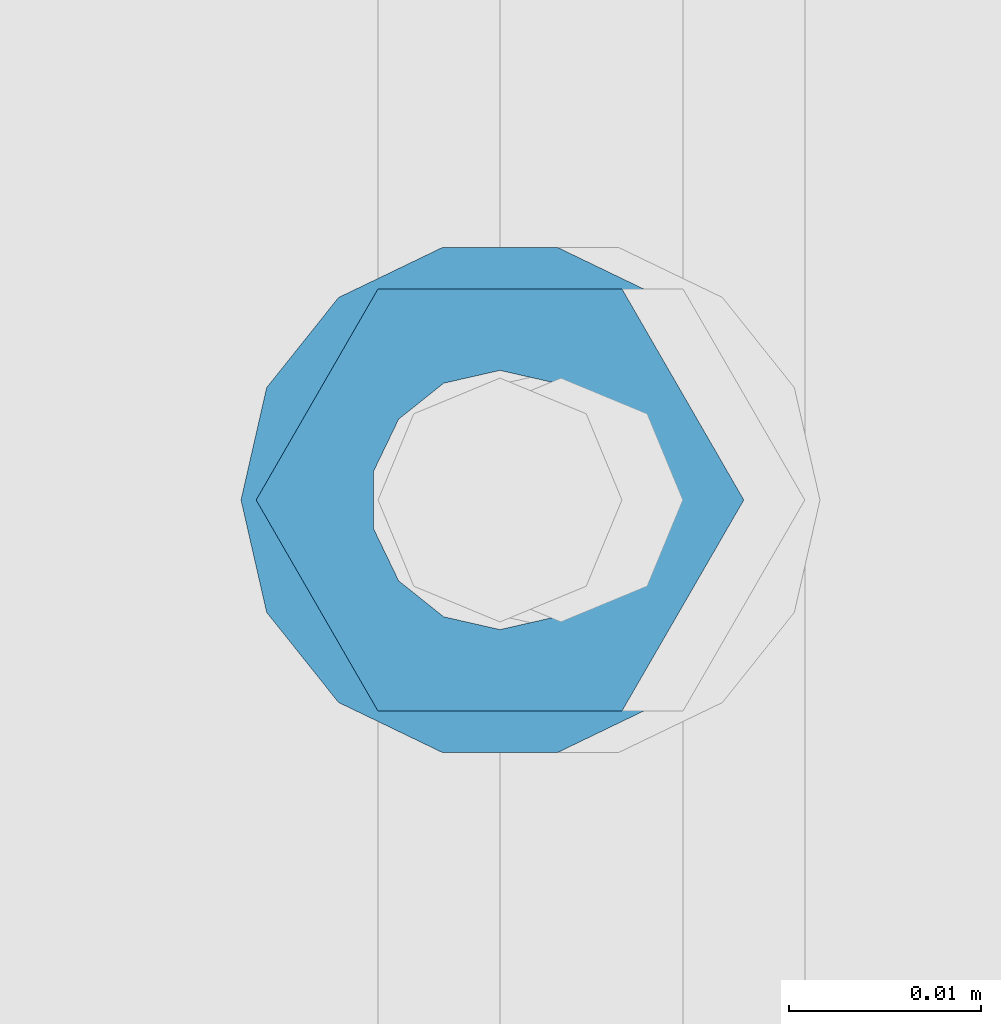
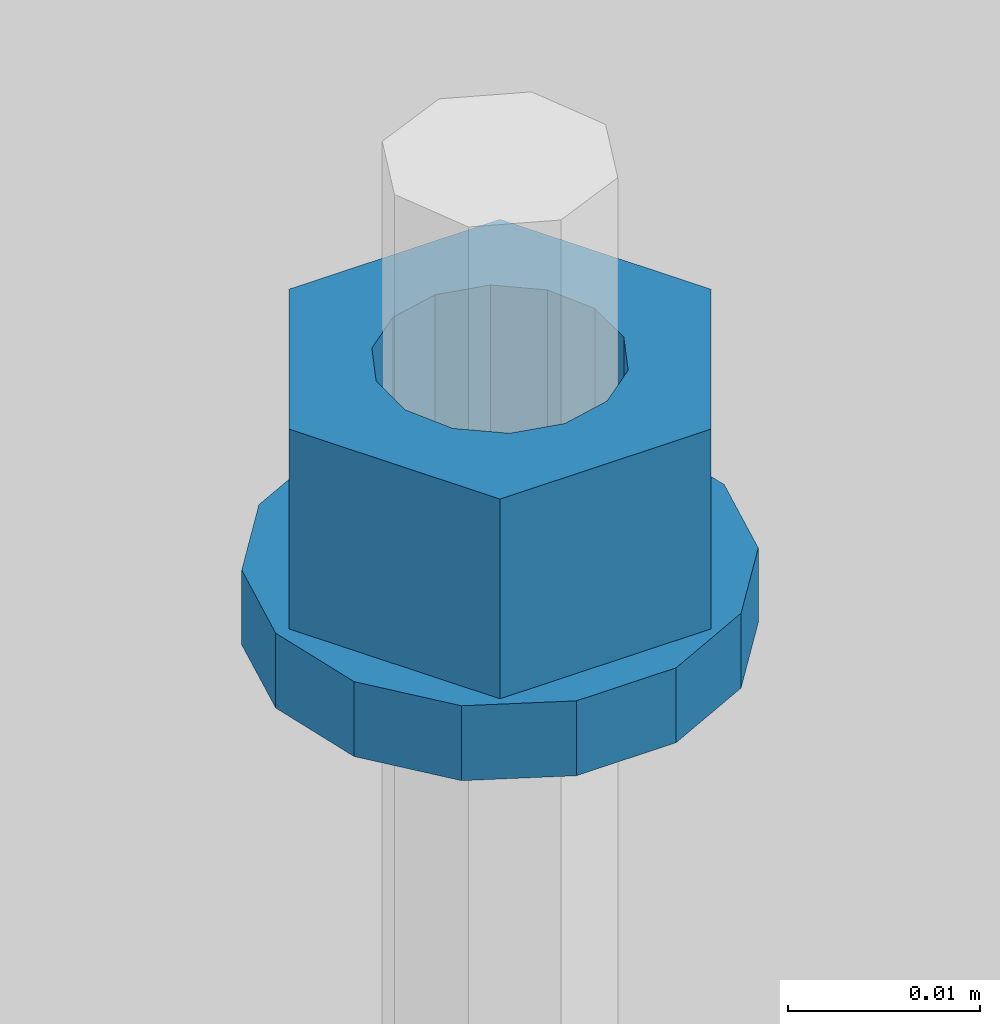
# One storey, part 686 of 1179: 2 columns, 1 element without a shape of its own.
"""IFC2X3 building model written with IfcOpenShell, lengths in millimetres."""

from ifc_helpers import new_model, si_unit, frame, origin_with_axes, place, context, subcontext, project, spatial, faceted_brep, material, type_object, element, aggregate, save


model = new_model("IFC2X3")

# Units and contexts
model_context = context("Model", 3, precision=1e-05, world=origin_with_axes())
body_context = subcontext(model_context, "Body", "Model", "MODEL_VIEW")
ifc_project = project(units=[si_unit("LENGTHUNIT", "METRE", prefix="MILLI"), si_unit("AREAUNIT", "SQUARE_METRE"), si_unit("VOLUMEUNIT", "CUBIC_METRE"), si_unit("MASSUNIT", "GRAM", prefix="KILO"), si_unit("TIMEUNIT", "SECOND"), si_unit("PLANEANGLEUNIT", "RADIAN"), si_unit("SOLIDANGLEUNIT", "STERADIAN"), si_unit("THERMODYNAMICTEMPERATUREUNIT", "DEGREE_CELSIUS"), si_unit("LUMINOUSINTENSITYUNIT", "LUMEN")], contexts=[model_context])

# Site, building, storey
site_placement = place(None, origin_with_axes())
site = spatial("IfcSite", under=ifc_project, at=site_placement, CompositionType="ELEMENT")
building_placement = place(site_placement, origin_with_axes())
building = spatial("IfcBuilding", under=site, at=building_placement, Name="Undefined", CompositionType="ELEMENT")
storey_placement = place(building_placement, origin_with_axes())
storey = spatial("IfcBuildingStorey", under=building, at=storey_placement, Name="Undefined", CompositionType="ELEMENT", Elevation=0.0)

# Assembly, columns
assembly_placement = place(storey_placement, origin_with_axes())
assembly = element("IfcElementAssembly", 1, at=assembly_placement, inside=storey, Name="BEAM", AssemblyPlace="NOTDEFINED", PredefinedType="RIGID_FRAME")
ifc_material = material(Name="STEEL/A307")
column_type_1 = type_object("IfcColumnType", Name="1/2_WASHER", PredefinedType="NOTDEFINED")
column_1_placement = place(assembly_placement, frame((13284.1999938965, 41529.0, 4235.45), z_axis=(0.0, 1.0, 0.0), x_axis=(0.0, 0.0, 1.0)))
column_1 = element("IfcColumn", 2, at=column_1_placement, type_object=column_type_1, material=ifc_material, Name="WASHER", ObjectType="1/2_WASHER", context=body_context, shape_type="Brep", body=[
    faceted_brep([(0.0, -13.4899997711182, 0.0), (0.0, -12.1540698217868, -5.85309154138758), (4.76249999999891, -12.1540698217868, -5.85309154138758), (4.76249999999891, -13.4899997711182, 0.0), (0.0, -8.41087728436833, -10.5469065195466), (4.76249999999891, -8.41087728436833, -10.5469065195466), (0.0, -3.00180734814057, -13.1517773121896), (4.76249999999891, -3.00180734814057, -13.1517773121896), (0.0, 3.00180734814057, -13.1517773121896), (4.76249999999891, 3.00180734814057, -13.1517773121896), (0.0, 8.41087728436833, -10.5469065195466), (4.76249999999891, 8.41087728436833, -10.5469065195466), (0.0, 12.1540698217868, -5.85309154138758), (4.76249999999891, 12.1540698217868, -5.85309154138758), (0.0, 13.4899997711182, 0.0), (4.76249999999891, 13.4899997711182, 0.0), (0.0, 12.1540698217868, 5.85309154138758), (4.76249999999891, 12.1540698217868, 5.85309154138758), (0.0, 8.41087728436833, 10.5469065195466), (4.76249999999891, 8.41087728436833, 10.5469065195466), (0.0, 3.00180734814057, 13.1517773121896), (4.76249999999891, 3.00180734814057, 13.1517773121896), (0.0, -3.00180734814057, 13.1517773121896), (4.76249999999891, -3.00180734814057, 13.1517773121896), (0.0, -8.41087728436833, 10.5469065195466), (4.76249999999891, -8.41087728436833, 10.5469065195466), (0.0, -12.1540698217868, 5.85309154138758), (4.76249999999891, -12.1540698217868, 5.85309154138758), (0.0, 0.0, 6.75), (0.0, 2.9287152390425, 6.08153985834178), (4.76249999999891, 2.9287152390425, 6.08153985834178), (4.76249999999891, 0.0, 6.75), (0.0, 5.27736250665839, 4.2085561625463), (4.76249999999891, 5.27736250665839, 4.2085561625463), (0.0, 6.58076340722619, 1.50201630420543), (4.76249999999891, 6.58076340722619, 1.50201630420543), (0.0, 6.58076340722619, -1.50201630420543), (4.76249999999891, 6.58076340722619, -1.50201630420543), (0.0, 5.27736250665839, -4.2085561625463), (4.76249999999891, 5.27736250665839, -4.2085561625463), (0.0, 2.9287152390425, -6.08153985834088), (4.76249999999891, 2.9287152390425, -6.08153985834088), (0.0, 0.0, -6.75), (4.76249999999891, 0.0, -6.75), (0.0, -2.9287152390425, -6.08153985834178), (4.76249999999891, -2.9287152390425, -6.08153985834178), (0.0, -5.27736250665839, -4.2085561625463), (4.76249999999891, -5.27736250665839, -4.2085561625463), (0.0, -6.58076340722619, -1.50201630420543), (4.76249999999891, -6.58076340722619, -1.50201630420543), (0.0, -6.58076340722619, 1.50201630420543), (4.76249999999891, -6.58076340722619, 1.50201630420543), (0.0, -5.27736250665839, 4.2085561625463), (4.76249999999891, -5.27736250665839, 4.2085561625463), (0.0, -2.9287152390425, 6.08153985834088), (4.76249999999891, -2.9287152390425, 6.08153985834088)], [[[0, 1, 2, 3]], [[1, 4, 5, 2]], [[4, 6, 7, 5]], [[6, 8, 9, 7]], [[8, 10, 11, 9]], [[10, 12, 13, 11]], [[12, 14, 15, 13]], [[14, 16, 17, 15]], [[16, 18, 19, 17]], [[18, 20, 21, 19]], [[20, 22, 23, 21]], [[22, 24, 25, 23]], [[24, 26, 27, 25]], [[26, 0, 3, 27]], [[28, 29, 30, 31]], [[29, 32, 33, 30]], [[32, 34, 35, 33]], [[34, 36, 37, 35]], [[36, 38, 39, 37]], [[38, 40, 41, 39]], [[40, 42, 43, 41]], [[42, 44, 45, 43]], [[44, 46, 47, 45]], [[46, 48, 49, 47]], [[48, 50, 51, 49]], [[50, 52, 53, 51]], [[52, 54, 55, 53]], [[54, 28, 31, 55]], [[5, 7, 9, 11, 13, 15, 17, 19, 21, 23, 25, 27, 3, 2], [33, 35, 37, 39, 41, 43, 45, 47, 49, 51, 53, 55, 31, 30]], [[26, 24, 22, 20, 18, 16, 14, 12, 10, 8, 6, 4, 1, 0], [54, 52, 50, 48, 46, 44, 42, 40, 38, 36, 34, 32, 29, 28]]]),
])
column_type_2 = type_object("IfcColumnType", Name="1/2_HEAVY_HEX_NUT", PredefinedType="NOTDEFINED")
column_2_placement = place(assembly_placement, frame((13284.1999938965, 41529.0, 4240.2125), z_axis=(0.0, 1.0, 0.0), x_axis=(0.0, 0.0, 1.0)))
column_2 = element("IfcColumn", 3, at=column_2_placement, type_object=column_type_2, material=ifc_material, Name="NUT", ObjectType="1/2_HEAVY_HEX_NUT", context=body_context, shape_type="Brep", body=[
    faceted_brep([(0.0, -12.7, 0.0), (0.0, -6.34999990463257, -11.0), (12.7000000000007, -6.34999990463257, -11.0), (12.7000000000007, -12.6999998092651, 0.0), (0.0, 6.34999990463257, -11.0), (12.7000000000007, 6.34999990463257, -11.0), (0.0, 12.7, 0.0), (12.7000000000007, 12.6999998092651, 0.0), (0.0, 6.34999990463257, 11.0), (12.7000000000007, 6.34999990463257, 11.0), (0.0, -6.34999990463257, 11.0), (12.7000000000007, -6.34999990463257, 11.0), (0.0, 0.0, 6.75), (0.0, 2.9287152390425, 6.08153985834178), (12.7000000000007, 2.9287152390425, 6.08153985834178), (12.7000000000007, 0.0, 6.75), (0.0, 5.27736250665839, 4.2085561625463), (12.7000000000007, 5.27736250665839, 4.2085561625463), (0.0, 6.58076340722619, 1.50201630420543), (12.7000000000007, 6.58076340722619, 1.50201630420543), (0.0, 6.58076340722619, -1.50201630420543), (12.7000000000007, 6.58076340722619, -1.50201630420543), (0.0, 5.27736250665839, -4.2085561625463), (12.7000000000007, 5.27736250665839, -4.2085561625463), (0.0, 2.9287152390425, -6.08153985834088), (12.7000000000007, 2.9287152390425, -6.08153985834088), (0.0, 0.0, -6.75), (12.7000000000007, 0.0, -6.75), (0.0, -2.9287152390425, -6.08153985834178), (12.7000000000007, -2.9287152390425, -6.08153985834178), (0.0, -5.27736250665839, -4.2085561625463), (12.7000000000007, -5.27736250665839, -4.2085561625463), (0.0, -6.58076340722619, -1.50201630420543), (12.7000000000007, -6.58076340722619, -1.50201630420543), (0.0, -6.58076340722619, 1.50201630420543), (12.7000000000007, -6.58076340722619, 1.50201630420543), (0.0, -5.27736250665839, 4.2085561625463), (12.7000000000007, -5.27736250665839, 4.2085561625463), (0.0, -2.9287152390425, 6.08153985834088), (12.7000000000007, -2.9287152390425, 6.08153985834088)], [[[0, 1, 2, 3]], [[1, 4, 5, 2]], [[4, 6, 7, 5]], [[6, 8, 9, 7]], [[8, 10, 11, 9]], [[10, 0, 3, 11]], [[12, 13, 14, 15]], [[13, 16, 17, 14]], [[16, 18, 19, 17]], [[18, 20, 21, 19]], [[20, 22, 23, 21]], [[22, 24, 25, 23]], [[24, 26, 27, 25]], [[26, 28, 29, 27]], [[28, 30, 31, 29]], [[30, 32, 33, 31]], [[32, 34, 35, 33]], [[34, 36, 37, 35]], [[36, 38, 39, 37]], [[38, 12, 15, 39]], [[5, 7, 9, 11, 3, 2], [17, 19, 21, 23, 25, 27, 29, 31, 33, 35, 37, 39, 15, 14]], [[10, 8, 6, 4, 1, 0], [38, 36, 34, 32, 30, 28, 26, 24, 22, 20, 18, 16, 13, 12]]]),
])
aggregate(assembly, [column_1, column_2])

save(model, "model.ifc")
